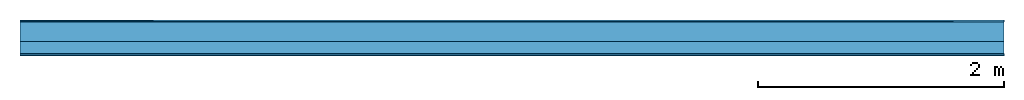
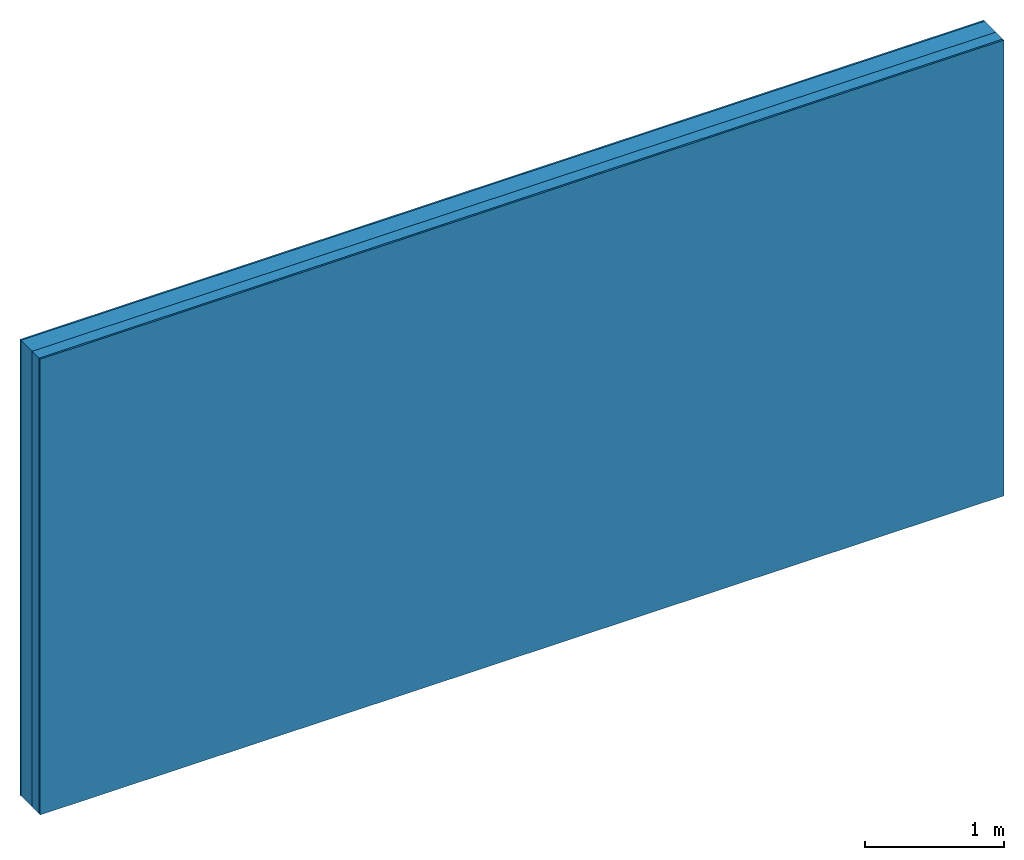
# One storey: 3 plates, 1 member, 1 element without a shape of its own.
"""IFC4 building model written with IfcOpenShell, lengths in metres."""

import ifcopenshell
import ifcopenshell.guid

model = None  # the IFC model being written
_history = None  # IfcOwnerHistory: only IFC2X3 demands one
_inside = {}  # id of a spatial element -> (the spatial element, [elements in it])
_under = {}  # id of a project, library or spatial element -> (it, [spatial elements below it])
_declared = {}  # id of a project -> (the project, [libraries it declares])
_typed = {}  # id of a type object -> (the type object, [elements of that type])
_made_of = {}  # id of a material, layer set ... -> (it, [elements and type objects made of it])


def new_model(schema):
    """Start an empty IFC model of exactly this schema.

    Asked for "IFC4X3", IfcOpenShell would pick the latest addendum, in which some entities
    have other attributes; the version numbers below select the first issue.
    IFC2X3 requires an IfcOwnerHistory on every rooted entity: one is made here for all.
    """
    global model, _history
    if schema == "IFC4X3":
        model = ifcopenshell.file(schema_version=(4, 3, 0, 0))
    else:
        model = ifcopenshell.file(schema=schema)
    _inside.clear()
    _under.clear()
    _declared.clear()
    _typed.clear()
    _made_of.clear()
    _history = None
    if model.schema == "IFC2X3":
        org = make("IfcOrganization", Name="unknown")
        user = make(
            "IfcPersonAndOrganization",
            ThePerson=make("IfcPerson", FamilyName="unknown"),
            TheOrganization=org,
        )
        app = make(
            "IfcApplication",
            ApplicationDeveloper=org,
            Version="unknown",
            ApplicationFullName="unknown",
            ApplicationIdentifier="unknown",
        )
        _history = make(
            "IfcOwnerHistory",
            OwningUser=user,
            OwningApplication=app,
            ChangeAction="ADDED",
            CreationDate=0,
        )
    return model


def make(cls, **values):
    """One entity of the class cls with the attributes given. An attribute that is None is left unset."""
    return model.create_entity(
        cls, **{name: value for name, value in values.items() if value is not None}
    )


def rooted(cls, **values):
    """An entity with a GlobalId (a new one), such as an element, a storey or a relation."""
    return make(cls, GlobalId=ifcopenshell.guid.new(), OwnerHistory=_history, **values)


def si_unit(unit_type, name, prefix=None):
    """IfcSIUnit, for example si_unit("LENGTHUNIT", "METRE", prefix="MILLI")."""
    return make("IfcSIUnit", UnitType=unit_type, Prefix=prefix, Name=name)


def derived_unit(unit_type, elements):
    """IfcDerivedUnit: a product of units, each with its exponent."""
    return make(
        "IfcDerivedUnit",
        Elements=[
            make("IfcDerivedUnitElement", Unit=unit, Exponent=power)
            for unit, power in elements
        ],
        UnitType=unit_type,
    )


def assignment(units):
    """IfcUnitAssignment: the units of a project."""
    return None if units is None else make("IfcUnitAssignment", Units=units)


def point(xyz):
    """IfcCartesianPoint."""
    return None if xyz is None else make("IfcCartesianPoint", Coordinates=xyz)


def direction(xyz):
    """IfcDirection."""
    return None if xyz is None else make("IfcDirection", DirectionRatios=xyz)


def frame(location, z_axis=None, x_axis=None):
    """IfcAxis2Placement3D, a coordinate frame: its origin and axes. An axis left out is left unset."""
    return make(
        "IfcAxis2Placement3D",
        Location=point(location),
        Axis=direction(z_axis),
        RefDirection=direction(x_axis),
    )


def frame_2d(location, x_axis=None):
    """IfcAxis2Placement2D, a coordinate frame in the plane: its origin and x axis."""
    return make(
        "IfcAxis2Placement2D", Location=point(location), RefDirection=direction(x_axis)
    )


def origin():
    """The frame at (0, 0, 0) with its axes left unset."""
    return frame((0.0, 0.0, 0.0))


def origin_with_axes():
    """The frame at (0, 0, 0) with the z axis (0, 0, 1) and the x axis (1, 0, 0) written out."""
    return frame((0.0, 0.0, 0.0), z_axis=(0.0, 0.0, 1.0), x_axis=(1.0, 0.0, 0.0))


def place(relative_to, where):
    """IfcLocalPlacement: puts the frame where relative to a parent placement (None: the world)."""
    return make(
        "IfcLocalPlacement", PlacementRelTo=relative_to, RelativePlacement=where
    )


def context(
    kind, dimensions, precision=None, world=None, true_north=None, identifier=None
):
    """IfcGeometricRepresentationContext, for example the 3D "Model" context."""
    return make(
        "IfcGeometricRepresentationContext",
        ContextIdentifier=identifier,
        ContextType=kind,
        CoordinateSpaceDimension=dimensions,
        Precision=precision,
        WorldCoordinateSystem=world,
        TrueNorth=true_north,
    )


def project(units=None, contexts=None):
    """IfcProject with its units and contexts."""
    return rooted(
        "IfcProject",
        Name="project",
        RepresentationContexts=contexts,
        UnitsInContext=assignment(units),
    )


def spatial(cls, under=None, at=None, **own):
    """A site, building, storey or space (cls), placed at a placement, below another one or the project."""
    s = rooted(cls, ObjectPlacement=at, **own)
    if under is not None:
        _under.setdefault(under.id(), (under, []))[1].append(s)
    return s


def profile(cls, at=None, kind="AREA", **sizes):
    """A parametric profile (cls). Its sizes go by their IFC names, for example OverallWidth=200.0."""
    return make(cls, ProfileType=kind, Position=at, **sizes)


def rectangle(**sizes):
    """IfcRectangleProfileDef."""
    return profile("IfcRectangleProfileDef", **sizes)


def extrude(swept, where, along, depth):
    """IfcExtrudedAreaSolid: the profile swept, set in the frame where, extruded along a direction by depth."""
    return make(
        "IfcExtrudedAreaSolid",
        SweptArea=swept,
        Position=where,
        ExtrudedDirection=direction(along),
        Depth=depth,
    )


def shape(context_of_items, identifier, shape_type, items):
    """IfcShapeRepresentation: the items that make up one representation, for example the "Body"."""
    return make(
        "IfcShapeRepresentation",
        ContextOfItems=context_of_items,
        RepresentationIdentifier=identifier,
        RepresentationType=shape_type,
        Items=items,
    )


def material(Name=None, Category=None):
    """IfcMaterial."""
    return make("IfcMaterial", Name=Name, Category=Category)


def layer(
    of_material, thickness, ventilated=None, Name=None, Category=None, Priority=None
):
    """IfcMaterialLayer: one layer of a wall or slab, of a material (None: an air gap)."""
    return make(
        "IfcMaterialLayer",
        Material=of_material,
        LayerThickness=thickness,
        IsVentilated=ventilated,
        Name=Name,
        Category=Category,
        Priority=Priority,
    )


def layer_set(layers, Name=None):
    """IfcMaterialLayerSet."""
    return make("IfcMaterialLayerSet", MaterialLayers=layers, LayerSetName=Name)


def made_of(thing, what):
    """Note that an element or type object is made of a material, layer set ...; save() writes the relation."""
    if what is not None:
        _made_of.setdefault(what.id(), (what, []))[1].append(thing)
    return thing


def type_object(cls, material=None, **own):
    """A type object (cls), such as IfcWallType, which elements share."""
    return made_of(rooted(cls, **own), material)


def element(
    cls,
    number,
    at=None,
    inside=None,
    cuts=None,
    type_object=None,
    material=None,
    context=None,
    identifier="Body",
    shape_type=None,
    held_by="IfcProductDefinitionShape",
    body=None,
    shapes=None,
    **own,
):
    """One element of the class cls, such as IfcWall. Its Tag is "e" and its number.

    at: its placement. inside: the storey or other place that contains it. cuts: it is an
    opening in that element (IfcRelVoidsElement). A single representation is given by context,
    identifier, shape_type and body (its items); several are given by shapes. held_by: the class
    of the entity that holds the representations. save() writes the other relations.
    """
    e = rooted(cls, Tag="e%d" % number, ObjectPlacement=at, **own)
    if body is not None:
        shapes = [shape(context, identifier, shape_type, body)]
    if shapes is not None:
        e.Representation = make(held_by, Representations=shapes)
    if inside is not None:
        _inside.setdefault(inside.id(), (inside, []))[1].append(e)
    if cuts is not None:
        rooted(
            "IfcRelVoidsElement", RelatingBuildingElement=cuts, RelatedOpeningElement=e
        )
    if type_object is not None:
        _typed.setdefault(type_object.id(), (type_object, []))[1].append(e)
    return made_of(e, material)


def aggregate(whole, parts):
    """IfcRelAggregates: a whole, such as a stair, and the parts it consists of."""
    return rooted("IfcRelAggregates", RelatingObject=whole, RelatedObjects=parts)


def save(model, path):
    """Write the relations noted so far, then the file.

    IfcRelAggregates (storeys below a building ...), IfcRelContainedInSpatialStructure (elements
    in a storey), IfcRelDefinesByType, IfcRelAssociatesMaterial and IfcRelDeclares: one each for
    every whole, place, type object, material and project.
    """
    for whole, parts in _under.values():
        aggregate(whole, parts)
    for where, things in _inside.values():
        rooted(
            "IfcRelContainedInSpatialStructure",
            RelatedElements=things,
            RelatingStructure=where,
        )
    for kind, things in _typed.values():
        rooted("IfcRelDefinesByType", RelatedObjects=things, RelatingType=kind)
    for what, things in _made_of.values():
        rooted("IfcRelAssociatesMaterial", RelatedObjects=things, RelatingMaterial=what)
    for by, libraries in _declared.values():
        rooted("IfcRelDeclares", RelatingContext=by, RelatedDefinitions=libraries)
    model.write(path)


model = new_model("IFC4")

# Units and contexts
plan_context = context("Plan", 3, precision=1e-05, world=origin(), true_north=direction((0.0, 1.0)))
model_context = context("Model", 3, precision=1e-05, world=origin(), true_north=direction((0.0, 1.0)))
ifc_project = project(units=[si_unit("LENGTHUNIT", "METRE"), derived_unit("SOUNDPRESSUREUNIT", [(si_unit("PRESSUREUNIT", "PASCAL", prefix="MICRO"), 0)]), si_unit("ENERGYUNIT", "JOULE", prefix="MEGA"), si_unit("MASSUNIT", "GRAM", prefix="KILO"), derived_unit("THERMALTRANSMITTANCEUNIT", [(si_unit("POWERUNIT", "WATT"), 1), (si_unit("AREAUNIT", "SQUARE_METRE"), -1), (si_unit("THERMODYNAMICTEMPERATUREUNIT", "KELVIN"), -1)]), derived_unit("AREADENSITYUNIT", [(si_unit("MASSUNIT", "GRAM", prefix="KILO"), 1), (si_unit("AREAUNIT", "SQUARE_METRE"), -1)]), derived_unit("USERDEFINED", [(si_unit("ENERGYUNIT", "JOULE", prefix="MEGA"), 1), (si_unit("AREAUNIT", "SQUARE_METRE"), -1)])], contexts=[plan_context, model_context])

# Site, building, storey
site = spatial("IfcSite", under=ifc_project)
building_placement = place(None, origin())
building = spatial("IfcBuilding", under=site, at=building_placement)
storey_placement = place(building_placement, origin())
storey = spatial("IfcBuildingStorey", under=building, at=storey_placement)

# Wall, member, plates
ifc_material_1 = material(Category="04.011")
ifc_layer_1 = layer(ifc_material_1, 0.015, Name="Surface 1")
ifc_material_2 = material(Category="10.009")
ifc_layer_2 = layer(ifc_material_2, 0.16, Name="outside 2nd layer")
ifc_material_3 = material(Name="of the art")
ifc_layer_3 = layer(ifc_material_3, 0.0, Name="Bond")
ifc_layer_4 = layer(None, 0.1, Name="Support")
ifc_layer_5 = layer(ifc_material_3, 0.0, Name="Bond")
ifc_material_4 = material(Category="03.007")
ifc_layer_6 = layer(ifc_material_4, 0.015, Name="1st layer")
ifc_layer_set = layer_set([ifc_layer_1, ifc_layer_2, ifc_layer_3, ifc_layer_4, ifc_layer_5, ifc_layer_6])
wall_type = type_object("IfcWallType", Name="D0928", PredefinedType="NOTDEFINED", material=ifc_layer_set)
wall_placement = place(None, frame((0.0, 0.0, 0.0), z_axis=(0.0, -1.0, 0.0), x_axis=(1.0, 0.0, 0.0)))
wall = element("IfcWall", 1, at=wall_placement, inside=storey, type_object=wall_type, material=ifc_layer_set, Name="Wall #1")
ifc_material_5 = material()
member_placement = place(wall_placement, origin())
member = element("IfcMember", 2, at=member_placement, material=ifc_material_5, Name="Support", context=plan_context, shape_type="SweptSolid", body=[
    extrude(rectangle(XDim=1.0, YDim=0.1, at=frame_2d((0.5, 0.05), x_axis=(1.0, 0.0))), frame((0.0, 4.0, 0.175), z_axis=(0.0, -1.0, 0.0), x_axis=(1.0, 0.0, 0.0)), (0.0, 0.0, 1.0), 4.0),
    extrude(rectangle(XDim=1.0, YDim=0.1, at=frame_2d((0.5, 0.05), x_axis=(1.0, 0.0))), frame((1.0, 4.0, 0.175), z_axis=(0.0, -1.0, 0.0), x_axis=(1.0, 0.0, 0.0)), (0.0, 0.0, 1.0), 4.0),
    extrude(rectangle(XDim=1.0, YDim=0.1, at=frame_2d((0.5, 0.05), x_axis=(1.0, 0.0))), frame((2.0, 4.0, 0.175), z_axis=(0.0, -1.0, 0.0), x_axis=(1.0, 0.0, 0.0)), (0.0, 0.0, 1.0), 4.0),
    extrude(rectangle(XDim=1.0, YDim=0.1, at=frame_2d((0.5, 0.05), x_axis=(1.0, 0.0))), frame((3.0, 4.0, 0.175), z_axis=(0.0, -1.0, 0.0), x_axis=(1.0, 0.0, 0.0)), (0.0, 0.0, 1.0), 4.0),
    extrude(rectangle(XDim=1.0, YDim=0.1, at=frame_2d((0.5, 0.05), x_axis=(1.0, 0.0))), frame((4.0, 4.0, 0.175), z_axis=(0.0, -1.0, 0.0), x_axis=(1.0, 0.0, 0.0)), (0.0, 0.0, 1.0), 4.0),
    extrude(rectangle(XDim=1.0, YDim=0.1, at=frame_2d((0.5, 0.05), x_axis=(1.0, 0.0))), frame((5.0, 4.0, 0.175), z_axis=(0.0, -1.0, 0.0), x_axis=(1.0, 0.0, 0.0)), (0.0, 0.0, 1.0), 4.0),
    extrude(rectangle(XDim=1.0, YDim=0.1, at=frame_2d((0.5, 0.05), x_axis=(1.0, 0.0))), frame((6.0, 4.0, 0.175), z_axis=(0.0, -1.0, 0.0), x_axis=(1.0, 0.0, 0.0)), (0.0, 0.0, 1.0), 4.0),
    extrude(rectangle(XDim=1.0, YDim=0.1, at=frame_2d((0.5, 0.05), x_axis=(1.0, 0.0))), frame((7.0, 4.0, 0.175), z_axis=(0.0, -1.0, 0.0), x_axis=(1.0, 0.0, 0.0)), (0.0, 0.0, 1.0), 4.0),
])
plate_1_placement = place(wall_placement, origin())
plate_1 = element("IfcPlate", 3, at=plate_1_placement, material=ifc_material_1, Name="Surface 1", context=plan_context, shape_type="SweptSolid", body=[
    extrude(rectangle(XDim=8.0, YDim=4.0, at=frame_2d((4.0, 2.0), x_axis=(1.0, 0.0))), origin_with_axes(), (0.0, 0.0, 1.0), 0.015),
])
plate_2_placement = place(wall_placement, origin())
plate_2 = element("IfcPlate", 4, at=plate_2_placement, material=ifc_material_2, Name="outside 2nd layer", context=plan_context, shape_type="SweptSolid", body=[
    extrude(rectangle(XDim=8.0, YDim=4.0, at=frame_2d((4.0, 2.0), x_axis=(1.0, 0.0))), frame((0.0, 0.0, 0.015), z_axis=(0.0, 0.0, 1.0), x_axis=(1.0, 0.0, 0.0)), (0.0, 0.0, 1.0), 0.16),
])
plate_3_placement = place(wall_placement, origin())
plate_3 = element("IfcPlate", 5, at=plate_3_placement, material=ifc_material_4, Name="1st layer", context=plan_context, shape_type="SweptSolid", body=[
    extrude(rectangle(XDim=8.0, YDim=4.0, at=frame_2d((4.0, 2.0), x_axis=(1.0, 0.0))), frame((0.0, 0.0, 0.275), z_axis=(0.0, 0.0, 1.0), x_axis=(1.0, 0.0, 0.0)), (0.0, 0.0, 1.0), 0.015),
])
aggregate(wall, [plate_1, plate_2, member, plate_3])

save(model, "model.ifc")
